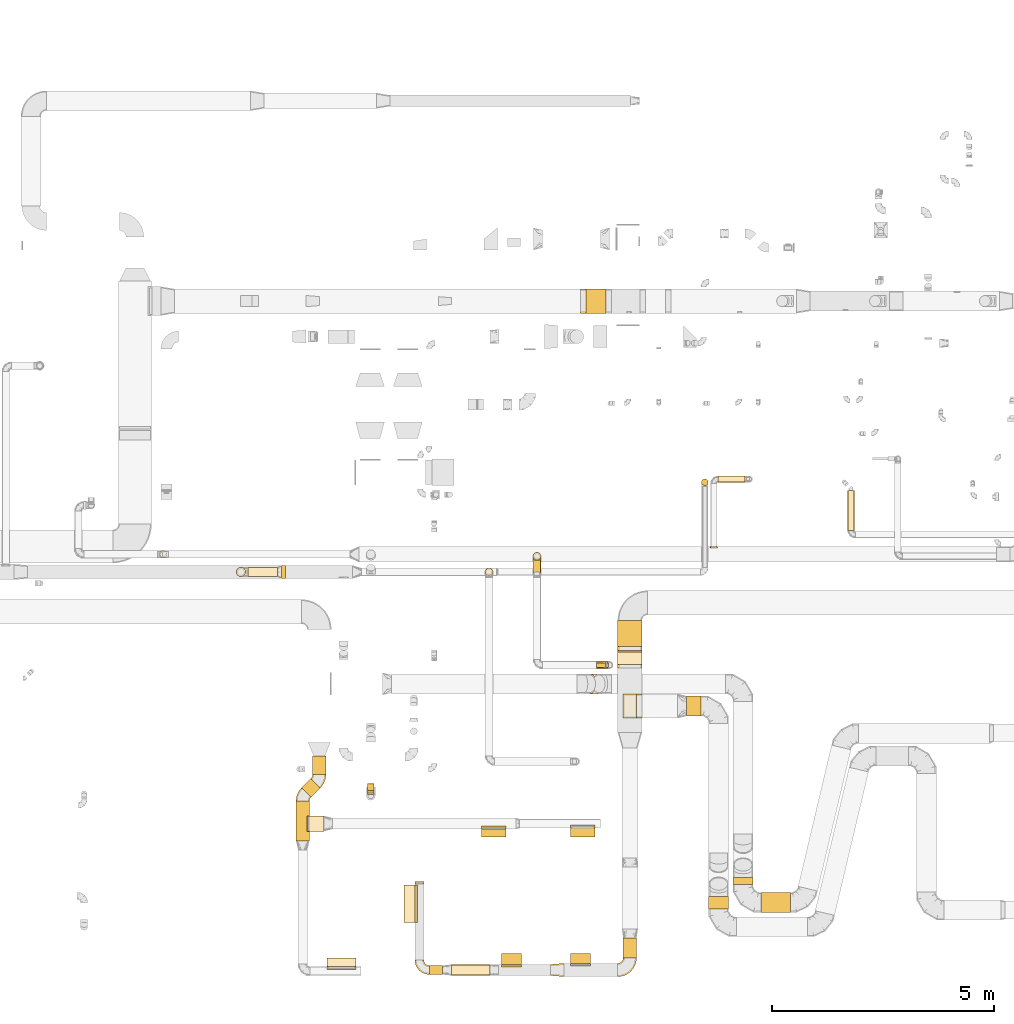
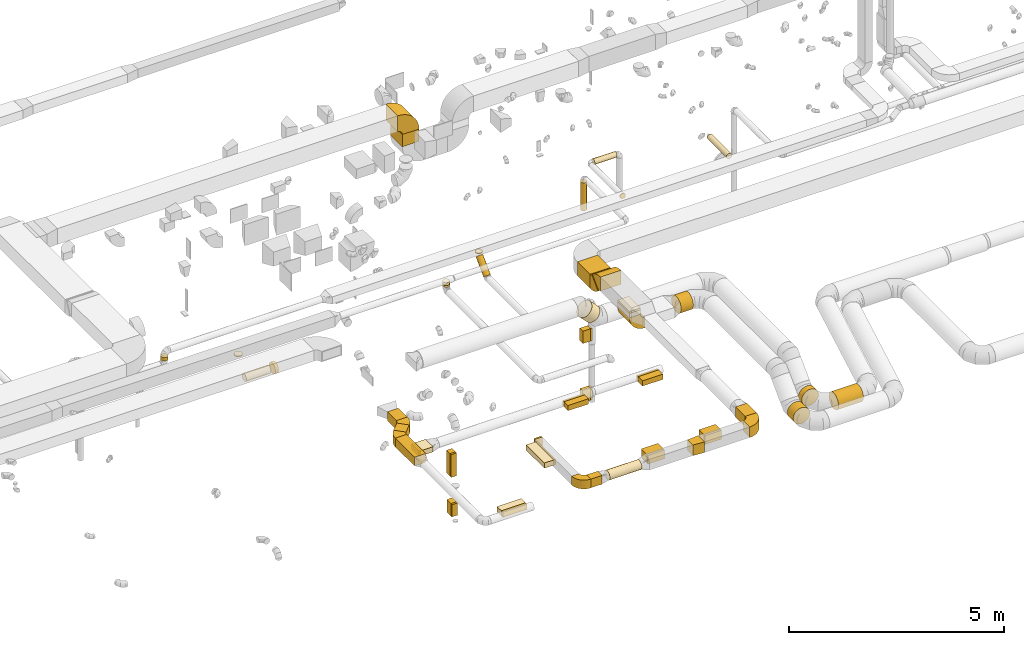
# One storey, part 7 of 97: 61 coverings.
"""IFC2X3 building model written with IfcOpenShell, lengths in millimetres."""

from ifc_helpers import new_model, entity, si_unit, converted_unit, derived_unit, direction, frame, frame_2d, origin, origin_2d_with_axis, place, context, subcontext, project, spatial, polyline, circle_curve, parameter, trimmed, segment, composite_curve, rectangle, circle, outline, extrude, element, save


model = new_model("IFC2X3")

# Units and contexts
model_context = context("Model", 3, precision=0.01, world=origin(), true_north=direction((6.12303176911189e-17, 1.0)))
body_context = subcontext(model_context, "Body", "Model", "MODEL_VIEW")
ifc_project = project(units=[si_unit("LENGTHUNIT", "METRE", prefix="MILLI"), si_unit("AREAUNIT", "SQUARE_METRE"), si_unit("VOLUMEUNIT", "CUBIC_METRE"), converted_unit("PLANEANGLEUNIT", "DEGREE", entity("IfcRatioMeasure", 0.0174532925199433), si_unit("PLANEANGLEUNIT", "RADIAN"), dimensions=[0, 0, 0, 0, 0, 0, 0]), si_unit("MASSUNIT", "GRAM", prefix="KILO"), derived_unit("MASSDENSITYUNIT", [(si_unit("MASSUNIT", "GRAM", prefix="KILO"), 1), (si_unit("LENGTHUNIT", "METRE"), -3)]), derived_unit("MOMENTOFINERTIAUNIT", [(si_unit("LENGTHUNIT", "METRE"), 4)]), si_unit("TIMEUNIT", "SECOND"), si_unit("FREQUENCYUNIT", "HERTZ"), si_unit("THERMODYNAMICTEMPERATUREUNIT", "DEGREE_CELSIUS"), derived_unit("THERMALTRANSMITTANCEUNIT", [(si_unit("MASSUNIT", "GRAM", prefix="KILO"), 1), (si_unit("THERMODYNAMICTEMPERATUREUNIT", "KELVIN"), -1), (si_unit("TIMEUNIT", "SECOND"), -3)]), derived_unit("VOLUMETRICFLOWRATEUNIT", [(si_unit("LENGTHUNIT", "METRE"), 3), (si_unit("TIMEUNIT", "SECOND"), -1)]), derived_unit("MASSFLOWRATEUNIT", [(si_unit("MASSUNIT", "GRAM", prefix="KILO"), 1), (si_unit("TIMEUNIT", "SECOND"), -1)]), derived_unit("ROTATIONALFREQUENCYUNIT", [(si_unit("TIMEUNIT", "SECOND"), -1)]), si_unit("ELECTRICCURRENTUNIT", "AMPERE"), si_unit("ELECTRICVOLTAGEUNIT", "VOLT"), si_unit("POWERUNIT", "WATT"), si_unit("FORCEUNIT", "NEWTON", prefix="KILO"), si_unit("ILLUMINANCEUNIT", "LUX"), si_unit("LUMINOUSFLUXUNIT", "LUMEN"), si_unit("LUMINOUSINTENSITYUNIT", "CANDELA"), derived_unit("USERDEFINED", [(si_unit("MASSUNIT", "GRAM", prefix="KILO"), -1), (si_unit("LENGTHUNIT", "METRE"), -2), (si_unit("TIMEUNIT", "SECOND"), 3), (si_unit("LUMINOUSFLUXUNIT", "LUMEN"), 1)]), derived_unit("LINEARVELOCITYUNIT", [(si_unit("LENGTHUNIT", "METRE"), 1), (si_unit("TIMEUNIT", "SECOND"), -1)]), si_unit("PRESSUREUNIT", "PASCAL"), derived_unit("USERDEFINED", [(si_unit("LENGTHUNIT", "METRE"), -2), (si_unit("MASSUNIT", "GRAM", prefix="KILO"), 1), (si_unit("TIMEUNIT", "SECOND"), -2)]), derived_unit("LINEARFORCEUNIT", [(si_unit("MASSUNIT", "GRAM", prefix="KILO"), 1), (si_unit("LENGTHUNIT", "METRE"), 1), (si_unit("TIMEUNIT", "SECOND"), -2), (si_unit("LENGTHUNIT", "METRE"), -1)]), derived_unit("PLANARFORCEUNIT", [(si_unit("MASSUNIT", "GRAM", prefix="KILO"), 1), (si_unit("LENGTHUNIT", "METRE"), 1), (si_unit("TIMEUNIT", "SECOND"), -2), (si_unit("LENGTHUNIT", "METRE"), -2)])], contexts=[model_context])

# Site, building, storey
site_placement = place(None, origin())
site = spatial("IfcSite", under=ifc_project, at=site_placement, CompositionType="ELEMENT")
building_placement = place(site_placement, origin())
building = spatial("IfcBuilding", under=site, at=building_placement, CompositionType="ELEMENT")
storey_placement = place(building_placement, frame((0.0, 0.0, -4900.0)))
storey = spatial("IfcBuildingStorey", under=building, at=storey_placement, CompositionType="ELEMENT", Elevation=-4900.0)

# Coverings
covering_1_placement = place(storey_placement, frame((51787.5, 2198.23, 2723.4)))
element("IfcCovering", 1, at=covering_1_placement, inside=storey, PredefinedType="INSULATION", context=body_context, shape_type="SweptSolid", body=[
    extrude(circle(Radius=225.0, at=origin_2d_with_axis()), frame((226.6, 0.0, 226.6), z_axis=(0.0, 1.0, 0.0), x_axis=(1.0, 0.0, 0.0)), (0.0, 0.0, 1.0), 161.222382101526),
])
covering_2_placement = place(storey_placement, frame((52414.1, 1571.63, 2723.4)))
element("IfcCovering", 2, at=covering_2_placement, inside=storey, PredefinedType="INSULATION", context=body_context, shape_type="SweptSolid", body=[
    extrude(circle(Radius=225.0, at=origin_2d_with_axis()), frame((0.0, 226.6, 226.6), z_axis=(1.0, 0.0, 0.0), x_axis=(0.0, -1.0, 0.0)), (0.0, 0.0, 1.0), 670.046048913268),
])
covering_3_placement = place(storey_placement, frame((41939.6, 3181.98, 3925.0)))
element("IfcCovering", 3, at=covering_3_placement, inside=storey, PredefinedType="INSULATION", context=body_context, shape_type="SweptSolid", body=[
    extrude(rectangle(XDim=895.203349597387, YDim=300.000000000001, at=origin_2d_with_axis()), frame((150.0, 447.6, 0.0), z_axis=(0.0, 0.0, 1.0), x_axis=(0.0, -1.0, 0.0)), (0.0, 0.0, 1.0), 250.0),
])
covering_4_placement = place(storey_placement, frame((42312.6, 4678.0, 3925.0)))
element("IfcCovering", 4, at=covering_4_placement, inside=storey, PredefinedType="INSULATION", context=body_context, shape_type="SweptSolid", body=[
    extrude(rectangle(XDim=419.303340347413, YDim=300.000000000001, at=origin_2d_with_axis()), frame((150.0, 209.65, 0.0), z_axis=(0.0, -4.68856683987599e-08, 1.0), x_axis=(0.0, 1.0, 4.68856683987599e-08)), (0.0, 0.0, 1.0), 250.0),
])
covering_5_placement = place(storey_placement, frame((42064.08, 4165.57, 3925.0)))
element("IfcCovering", 5, at=covering_5_placement, inside=storey, PredefinedType="INSULATION", context=body_context, shape_type="SweptSolid", body=[
    extrude(rectangle(XDim=299.684199460135, YDim=300.00000000001, at=origin_2d_with_axis()), frame((212.02, 212.02, 0.0), z_axis=(0.0, 0.0, 1.0), x_axis=(0.707106781186551, 0.707106781186544, 0.0)), (0.0, 0.0, 1.0), 250.0),
])
covering_6_placement = place(storey_placement, frame((42637.03, 348.86, 3975.0)))
element("IfcCovering", 6, at=covering_6_placement, inside=storey, PredefinedType="INSULATION", context=body_context, shape_type="SweptSolid", body=[
    extrude(rectangle(XDim=200.0, YDim=650.000000000008, at=origin_2d_with_axis()), frame((325.0, 100.0, 0.0), z_axis=(0.0, 0.0, 1.0), x_axis=(0.0, 1.0, 0.0)), (0.0, 0.0, 1.0), 150.0),
])
covering_7_placement = place(storey_placement, frame((42637.03, 280.22, 3975.0)))
element("IfcCovering", 7, at=covering_7_placement, inside=storey, PredefinedType="INSULATION", context=body_context, shape_type="SweptSolid", body=[
    extrude(rectangle(XDim=68.6460200160135, YDim=650.0, at=origin_2d_with_axis()), frame((325.0, 34.32, 0.0), z_axis=(0.0, 0.0, 1.0), x_axis=(0.0, -1.0, 0.0)), (0.0, 0.0, 1.0), 150.0),
])
covering_8_placement = place(storey_placement, frame((42183.5, 3398.53, 3975.0)))
element("IfcCovering", 8, at=covering_8_placement, inside=storey, PredefinedType="INSULATION", context=body_context, shape_type="SweptSolid", body=[
    extrude(rectangle(XDim=51.0960000000189, YDim=350.0, at=origin_2d_with_axis()), frame((25.55, 175.0, 0.0), z_axis=(0.0, 0.0, 1.0), x_axis=(-1.0, 0.0, 0.0)), (0.0, 0.0, 1.0), 150.0),
])
covering_9_placement = place(storey_placement, frame((42234.6, 3398.53, 3975.0)))
element("IfcCovering", 9, at=covering_9_placement, inside=storey, PredefinedType="INSULATION", context=body_context, shape_type="SweptSolid", body=[
    extrude(rectangle(XDim=330.308660000007, YDim=350.000000000001, at=origin_2d_with_axis()), frame((165.15, 175.0, 0.0)), (0.0, 0.0, 1.0), 150.0),
])
covering_10_placement = place(storey_placement, frame((48123.45, 3273.53, 3975.0)))
element("IfcCovering", 10, at=covering_10_placement, inside=storey, PredefinedType="INSULATION", context=body_context, shape_type="SweptSolid", body=[
    extrude(rectangle(XDim=199.999971499982, YDim=549.999999999996, at=origin_2d_with_axis()), frame((275.0, 100.0, 0.0), z_axis=(0.0, 0.0, 1.0), x_axis=(0.0, -1.0, 0.0)), (0.0, 0.0, 1.0), 150.0),
])
covering_11_placement = place(storey_placement, frame((46119.41, 3273.53, 3975.0)))
element("IfcCovering", 11, at=covering_11_placement, inside=storey, PredefinedType="INSULATION", context=body_context, shape_type="SweptSolid", body=[
    extrude(rectangle(XDim=179.999983999988, YDim=549.999999999996, at=origin_2d_with_axis()), frame((275.0, 90.0, 0.0), z_axis=(0.0, 0.0, 1.0), x_axis=(0.0, -1.0, 0.0)), (0.0, 0.0, 1.0), 150.0),
])
covering_12_placement = place(storey_placement, frame((46119.41, 3453.53, 3975.0)))
element("IfcCovering", 12, at=covering_12_placement, inside=storey, PredefinedType="INSULATION", context=body_context, shape_type="SweptSolid", body=[
    extrude(rectangle(XDim=549.999999999996, YDim=64.4934596215618, at=origin_2d_with_axis()), frame((275.0, 32.25, 0.0)), (0.0, 0.0, 1.0), 150.0),
])
covering_13_placement = place(storey_placement, frame((48123.45, 3473.53, 3975.0)))
element("IfcCovering", 13, at=covering_13_placement, inside=storey, PredefinedType="INSULATION", context=body_context, shape_type="SweptSolid", body=[
    extrude(rectangle(XDim=549.999999999996, YDim=68.6460200160276, at=origin_2d_with_axis()), frame((275.0, 34.32, 0.0)), (0.0, 0.0, 1.0), 150.0),
])
covering_14_placement = place(storey_placement, frame((40857.67, 9138.41, 3040.4)))
element("IfcCovering", 14, at=covering_14_placement, inside=storey, PredefinedType="INSULATION", context=body_context, shape_type="SweptSolid", body=[
    extrude(circle(Radius=105.0, at=origin_2d_with_axis()), frame((0.0, 106.6, 106.6), z_axis=(1.0, 0.0, 0.0), x_axis=(0.0, 1.0, 0.0)), (0.0, 0.0, 1.0), 663.702439249885),
])
covering_15_placement = place(storey_placement, frame((41611.37, 9093.41, 2995.4)))
element("IfcCovering", 15, at=covering_15_placement, inside=storey, PredefinedType="INSULATION", context=body_context, shape_type="SweptSolid", body=[
    extrude(circle(Radius=150.0, at=origin_2d_with_axis()), frame((0.0, 151.6, 151.6), z_axis=(1.0, 0.0, 0.0), x_axis=(0.0, 1.0, 0.0)), (0.0, 0.0, 1.0), 90.0000000000315),
])
covering_16_placement = place(storey_placement, frame((51076.93, 11188.41, 3100.0)))
element("IfcCovering", 16, at=covering_16_placement, inside=storey, PredefinedType="INSULATION", context=body_context, shape_type="SweptSolid", body=[
    extrude(circle(Radius=75.0, at=origin_2d_with_axis()), frame((76.6, 76.6, 0.0)), (0.0, 0.0, 1.0), 799.999999999995),
])
covering_17_placement = place(storey_placement, frame((46200.29, 9155.91, 3865.0)))
element("IfcCovering", 17, at=covering_17_placement, inside=storey, PredefinedType="INSULATION", context=body_context, shape_type="SweptSolid", body=[
    extrude(circle(Radius=87.5, at=origin_2d_with_axis()), frame((89.1, 89.1, 0.0), z_axis=(0.0, 1.27955975282367e-05, 1.0), x_axis=(0.0, 1.0, -1.27955975282367e-05)), (0.0, 0.0, 1.0), 52.503404808983),
])
covering_18_placement = place(storey_placement, frame((49188.6, 7564.08, 3780.0)))
element("IfcCovering", 18, at=covering_18_placement, inside=storey, PredefinedType="INSULATION", context=body_context, shape_type="SweptSolid", body=[
    extrude(rectangle(XDim=586.289807584145, YDim=549.999999999996, at=origin_2d_with_axis()), frame((275.0, 293.14, 0.0), z_axis=(0.0, 0.0, 1.0), x_axis=(0.0, -1.0, 0.0)), (0.0, 0.0, 1.0), 400.0),
])
covering_19_placement = place(storey_placement, frame((49188.6, 7163.23, 3933.77)))
element("IfcCovering", 19, at=covering_19_placement, inside=storey, PredefinedType="INSULATION", context=body_context, shape_type="SweptSolid", body=[
    extrude(rectangle(XDim=41.888132824211, YDim=400.0, at=origin_2d_with_axis()), frame((0.0, 156.23, 156.23), z_axis=(1.0, 0.0, 0.0), x_axis=(0.0, -0.707106781186528, 0.707106781186567)), (0.0, 0.0, 1.0), 550.000000000005),
])
covering_20_placement = place(storey_placement, frame((49313.6, 548.87, 4050.0)))
element("IfcCovering", 20, at=covering_20_placement, inside=storey, PredefinedType="INSULATION", context=body_context, shape_type="SweptSolid", body=[
    extrude(rectangle(XDim=446.507916250006, YDim=300.000000000001, at=origin_2d_with_axis()), frame((150.0, 223.25, 0.0), z_axis=(0.0, 9.6225856577518e-09, 1.0), x_axis=(0.0, -1.0, 9.6225856577518e-09)), (0.0, 0.0, 1.0), 300.0),
])
covering_21_placement = place(storey_placement, frame((47673.94, 123.87, 4050.0)))
element("IfcCovering", 21, at=covering_21_placement, inside=storey, PredefinedType="INSULATION", context=body_context, shape_type="SweptSolid", body=[
    extrude(outline(polyline([(-161.94, -137.03), (139.1, -137.03), (159.86, 112.11), (-137.03, 161.94), (-161.94, -137.03)])), frame((150.0, 150.0, 0.0), z_axis=(0.0, 0.0, 1.0), x_axis=(-0.996545758244898, -0.0830454798535242, 0.0)), (0.0, 0.0, 1.0), 300.0),
])
covering_22_placement = place(storey_placement, frame((48125.01, 418.87, 4075.0)))
element("IfcCovering", 22, at=covering_22_placement, inside=storey, PredefinedType="INSULATION", context=body_context, shape_type="SweptSolid", body=[
    extrude(rectangle(XDim=229.999999999978, YDim=450.000000000002, at=origin_2d_with_axis()), frame((225.0, 115.0, 0.0), z_axis=(0.0, 0.0, 1.0), x_axis=(0.0, 1.0, 0.0)), (0.0, 0.0, 1.0), 250.0),
])
covering_23_placement = place(storey_placement, frame((46575.54, 393.87, 4075.0)))
element("IfcCovering", 23, at=covering_23_placement, inside=storey, PredefinedType="INSULATION", context=body_context, shape_type="SweptSolid", body=[
    extrude(rectangle(XDim=254.999999999911, YDim=450.000000000002, at=origin_2d_with_axis()), frame((225.0, 127.5, 0.0), z_axis=(0.0, 0.0, 1.0), x_axis=(0.0, 1.0, 0.0)), (0.0, 0.0, 1.0), 250.0),
])
for number, where in (
    (24, (48125.01, 367.78, 4075.0)),
    (25, (46575.54, 342.78, 4075.0)),
):
    element("IfcCovering", number, at=place(storey_placement, frame(where)), inside=storey, PredefinedType="INSULATION", context=body_context, shape_type="SweptSolid", body=[
        extrude(rectangle(XDim=450.000000000002, YDim=51.0959999999993, at=origin_2d_with_axis()), frame((225.0, 25.55, 0.0), z_axis=(0.0, 0.0, 1.0), x_axis=(-1.0, 0.0, 0.0)), (0.0, 0.0, 1.0), 250.0),
    ])
covering_24_placement = place(storey_placement, frame((45443.8, 147.28, 4073.4)))
element("IfcCovering", 26, at=covering_24_placement, inside=storey, PredefinedType="INSULATION", context=body_context, shape_type="SweptSolid", body=[
    extrude(circle(Radius=125.0, at=origin_2d_with_axis()), frame((0.0, 126.6, 126.6), z_axis=(1.0, 0.0, 0.0), x_axis=(0.0, -1.0, 0.0)), (0.0, 0.0, 1.0), 862.329403500012),
])
covering_25_placement = place(storey_placement, frame((44943.59, 173.87, 4075.0)))
element("IfcCovering", 27, at=covering_25_placement, inside=storey, PredefinedType="INSULATION", context=body_context, shape_type="SweptSolid", body=[
    extrude(rectangle(XDim=300.204466499987, YDim=200.0, at=origin_2d_with_axis()), frame((150.1, 100.0, 0.0), z_axis=(0.0, 0.0, 1.0), x_axis=(-1.0, 0.0, 0.0)), (0.0, 0.0, 1.0), 250.0),
])
covering_26_placement = place(storey_placement, frame((44618.59, 2217.15, 4075.0)))
element("IfcCovering", 28, at=covering_26_placement, inside=storey, PredefinedType="INSULATION", context=body_context, shape_type="SweptSolid", body=[
    extrude(rectangle(XDim=50.0000000000005, YDim=199.999999999998, at=origin_2d_with_axis()), frame((100.0, 25.0, 0.0), z_axis=(0.0, 0.0, 1.0), x_axis=(0.0, -1.0, 0.0)), (0.0, 0.0, 1.0), 250.0),
])
covering_27_placement = place(storey_placement, frame((44368.59, 1341.12, 4125.0)))
element("IfcCovering", 29, at=covering_27_placement, inside=storey, PredefinedType="INSULATION", context=body_context, shape_type="SweptSolid", body=[
    extrude(rectangle(XDim=254.999966500009, YDim=850.0, at=origin_2d_with_axis()), frame((127.5, 425.0, 0.0), z_axis=(0.0, 0.0, 1.0), x_axis=(-1.0, 0.0, 0.0)), (0.0, 0.0, 1.0), 150.0),
])
covering_28_placement = place(storey_placement, frame((44623.59, 1341.12, 4125.0)))
element("IfcCovering", 30, at=covering_28_placement, inside=storey, PredefinedType="INSULATION", context=body_context, shape_type="SweptSolid", body=[
    extrude(rectangle(XDim=850.0, YDim=51.0960000000016, at=origin_2d_with_axis()), frame((25.55, 425.0, 0.0), z_axis=(0.0, 0.0, 1.0), x_axis=(0.0, -1.0, 0.0)), (0.0, 0.0, 1.0), 150.0),
])
covering_29_placement = place(storey_placement, frame((49313.6, 5948.55, 3875.0)))
element("IfcCovering", 31, at=covering_29_placement, inside=storey, PredefinedType="INSULATION", context=body_context, shape_type="SweptSolid", body=[
    extrude(rectangle(XDim=550.000000000001, YDim=300.000000000001, at=origin_2d_with_axis()), frame((150.0, 275.0, 0.0), z_axis=(0.0, 0.0, 1.0), x_axis=(0.0, 1.0, 0.0)), (0.0, 0.0, 1.0), 129.99999999994),
])
covering_30_placement = place(storey_placement, frame((49313.6, 5948.55, 4005.0)))
element("IfcCovering", 32, at=covering_30_placement, inside=storey, PredefinedType="INSULATION", context=body_context, shape_type="SweptSolid", body=[
    extrude(rectangle(XDim=550.0, YDim=300.000000000001, at=origin_2d_with_axis()), frame((150.0, 275.0, 0.0), z_axis=(0.0, 0.0, 1.0), x_axis=(0.0, 1.0, 0.0)), (0.0, 0.0, 1.0), 51.0960000001598),
])
covering_31_placement = place(storey_placement, frame((50735.84, 5996.95, 3373.4)))
element("IfcCovering", 33, at=covering_31_placement, inside=storey, PredefinedType="INSULATION", context=body_context, shape_type="SweptSolid", body=[
    extrude(circle(Radius=225.0, at=origin_2d_with_axis()), frame((0.0, 226.6, 226.6), z_axis=(1.0, 0.0, 4.02178412496961e-08), x_axis=(0.0, 1.0, 0.0)), (0.0, 0.0, 1.0), 328.315702253714),
])
covering_32_placement = place(storey_placement, frame((51237.56, 1648.73, 2723.4)))
element("IfcCovering", 34, at=covering_32_placement, inside=storey, PredefinedType="INSULATION", context=body_context, shape_type="SweptSolid", body=[
    extrude(circle(Radius=225.0, at=origin_2d_with_axis()), frame((226.6, 0.0, 226.6), z_axis=(0.0, 1.0, 0.0), x_axis=(1.0, 0.0, 0.0)), (0.0, 0.0, 1.0), 279.135993523077),
])
covering_33_placement = place(storey_placement, frame((47279.85, 9509.05, 4221.78)))
element("IfcCovering", 35, at=covering_33_placement, inside=storey, PredefinedType="INSULATION", context=body_context, shape_type="SweptSolid", body=[
    extrude(circle(Radius=87.5, at=origin_2d_with_axis()), frame((89.1, 89.1, 0.0), z_axis=(0.0, 0.0, 1.0), x_axis=(0.0, 1.0, 0.0)), (0.0, 0.0, 1.0), 8.22330470336942),
])
covering_34_placement = place(storey_placement, frame((48711.88, 7071.24, 2675.0)))
element("IfcCovering", 36, at=covering_34_placement, inside=storey, PredefinedType="INSULATION", context=body_context, shape_type="SweptSolid", body=[
    extrude(rectangle(XDim=204.999967249919, YDim=150.000000000001, at=origin_2d_with_axis()), frame((102.5, 75.0, 0.0), z_axis=(0.0, 0.0, 1.0), x_axis=(-1.0, 0.0, 0.0)), (0.0, 0.0, 1.0), 350.0),
])
covering_35_placement = place(storey_placement, frame((48711.74, 7096.24, 975.0)))
element("IfcCovering", 37, at=covering_35_placement, inside=storey, PredefinedType="INSULATION", context=body_context, shape_type="SweptSolid", body=[
    extrude(rectangle(XDim=217.638826253178, YDim=100.000000000001, at=origin_2d_with_axis()), frame((108.82, 50.0, 0.0), z_axis=(0.0, 0.0, 1.0), x_axis=(-1.0, 0.0, 0.0)), (0.0, 0.0, 1.0), 350.000000000001),
])
covering_36_placement = place(storey_placement, frame((48929.38, 7096.24, 975.0)))
element("IfcCovering", 38, at=covering_36_placement, inside=storey, PredefinedType="INSULATION", context=body_context, shape_type="SweptSolid", body=[
    extrude(rectangle(XDim=100.000000000001, YDim=51.0960000000102, at=origin_2d_with_axis()), frame((25.55, 50.0, 0.0), z_axis=(0.0, 0.0, 1.0), x_axis=(0.0, -1.0, 0.0)), (0.0, 0.0, 1.0), 350.0),
])
covering_37_placement = place(storey_placement, frame((48916.88, 7071.24, 2675.0)))
element("IfcCovering", 39, at=covering_37_placement, inside=storey, PredefinedType="INSULATION", context=body_context, shape_type="SweptSolid", body=[
    extrude(rectangle(XDim=150.000000000001, YDim=51.0960000001488, at=origin_2d_with_axis()), frame((25.55, 75.0, 0.0), z_axis=(0.0, 0.0, 1.0), x_axis=(0.0, -1.0, 0.0)), (0.0, 0.0, 1.0), 350.0),
])
covering_38_placement = place(storey_placement, frame((43550.66, 4318.32, 2375.0)))
element("IfcCovering", 40, at=covering_38_placement, inside=storey, PredefinedType="INSULATION", context=body_context, shape_type="SweptSolid", body=[
    extrude(rectangle(XDim=159.99999999999, YDim=150.000000000002, at=origin_2d_with_axis()), frame((75.0, 80.0, 0.0), z_axis=(0.0, 0.0, 1.0), x_axis=(-9.81578986625269e-06, 1.0, 0.0)), (0.0, 0.0, 1.0), 649.999999999999),
])
covering_39_placement = place(storey_placement, frame((43550.66, 4280.82, 1275.0)))
element("IfcCovering", 41, at=covering_39_placement, inside=storey, PredefinedType="INSULATION", context=body_context, shape_type="SweptSolid", body=[
    extrude(rectangle(XDim=189.999999999926, YDim=150.000000000001, at=origin_2d_with_axis()), frame((75.0, 95.0, 0.0), z_axis=(0.0, 0.0, 1.0), x_axis=(0.0, 1.0, 0.0)), (0.0, 0.0, 1.0), 350.000000000001),
])
covering_40_placement = place(storey_placement, frame((43550.66, 4267.22, 2375.0)))
element("IfcCovering", 42, at=covering_40_placement, inside=storey, PredefinedType="INSULATION", context=body_context, shape_type="SweptSolid", body=[
    extrude(rectangle(XDim=150.000000000002, YDim=51.0960000000012, at=origin_2d_with_axis()), frame((75.0, 25.55, 0.0), z_axis=(0.0, 0.0, 1.0), x_axis=(-1.0, -9.81578986625197e-06, 0.0)), (0.0, 0.0, 1.0), 649.999999999999),
])
covering_41_placement = place(storey_placement, frame((43550.66, 4229.72, 1275.0)))
element("IfcCovering", 43, at=covering_41_placement, inside=storey, PredefinedType="INSULATION", context=body_context, shape_type="SweptSolid", body=[
    extrude(rectangle(XDim=150.000000000001, YDim=51.0960000001477, at=origin_2d_with_axis()), frame((75.0, 25.55, 0.0), z_axis=(0.0, 0.0, 1.0), x_axis=(-1.0, 0.0, 0.0)), (0.0, 0.0, 1.0), 350.0),
])
covering_42_placement = place(storey_placement, frame((54370.31, 10183.58, 4038.4)))
element("IfcCovering", 44, at=covering_42_placement, inside=storey, PredefinedType="INSULATION", context=body_context, shape_type="SweptSolid", body=[
    extrude(circle(Radius=75.0, at=origin_2d_with_axis()), frame((76.6, 0.0, 76.6), z_axis=(0.0, 1.0, 0.0), x_axis=(-1.0, 0.0, 0.0)), (0.0, 0.0, 1.0), 895.739513762699),
])
covering_43_placement = place(storey_placement, frame((48388.84, 6496.49, 3556.46)))
element("IfcCovering", 45, at=covering_43_placement, inside=storey, PredefinedType="INSULATION", context=body_context, shape_type="SweptSolid", body=[
    extrude(circle(Radius=225.0, at=origin_2d_with_axis()), frame((376.38, 226.6, 160.69), z_axis=(-0.707106781186547, 0.0, 0.707106781186548), x_axis=(0.0, 1.0, 0.0)), (0.0, 0.0, 1.0), 305.025253169393),
])
covering_44_placement = place(storey_placement, frame((51454.28, 11258.75, 4223.4)))
element("IfcCovering", 46, at=covering_44_placement, inside=storey, PredefinedType="INSULATION", context=body_context, shape_type="SweptSolid", body=[
    extrude(circle(Radius=75.0, at=origin_2d_with_axis()), frame((0.0, 76.6, 76.6), z_axis=(1.0, 0.0, 0.0), x_axis=(0.0, -1.0, 0.0)), (0.0, 0.0, 1.0), 600.000000000011),
])
covering_45_placement = place(storey_placement, frame((51277.68, 9787.05, 4223.4)))
element("IfcCovering", 47, at=covering_45_placement, inside=storey, PredefinedType="INSULATION", context=body_context, shape_type="SweptSolid", body=[
    extrude(circle(Radius=75.0, at=origin_2d_with_axis()), frame((76.6, 0.0, 76.6), z_axis=(0.0, 1.0, 0.0), x_axis=(-1.0, 0.0, 0.0)), (0.0, 0.0, 1.0), 26.0959999999964),
])
covering_46_placement = place(storey_placement, frame((38850.72, 9554.05, 4105.0)))
element("IfcCovering", 48, at=covering_46_placement, inside=storey, PredefinedType="INSULATION", context=body_context, shape_type="SweptSolid", body=[
    extrude(circle(Radius=87.5, at=origin_2d_with_axis()), frame((89.1, 89.1, 0.0), z_axis=(0.0, 0.0, 1.0), x_axis=(0.0, -1.0, 0.0)), (0.0, 0.0, 1.0), 95.0000000000028),
])
covering_47_placement = place(storey_placement, frame((40591.08, 9138.41, 3855.0)))
element("IfcCovering", 49, at=covering_47_placement, inside=storey, PredefinedType="INSULATION", context=body_context, shape_type="SweptSolid", body=[
    extrude(circle(Radius=105.0, at=origin_2d_with_axis()), frame((106.6, 106.6, 0.0)), (0.0, 0.0, 1.0), 26.096000000207),
])
covering_48_placement = place(storey_placement, frame((48477.19, 15074.1, 3500.0)))
element("IfcCovering", 50, at=covering_48_placement, inside=storey, PredefinedType="INSULATION", context=body_context, shape_type="SweptSolid", body=[
    extrude(rectangle(XDim=550.000000000001, YDim=450.000000000002, at=origin_2d_with_axis()), frame((225.0, 275.0, 0.0), z_axis=(0.0, 0.0, 1.0), x_axis=(0.0, 1.0, 0.0)), (0.0, 0.0, 1.0), 349.999974999914),
])
covering_49_placement = place(storey_placement, frame((46200.29, 9155.91, 3917.5)))
element("IfcCovering", 51, at=covering_49_placement, inside=storey, PredefinedType="INSULATION", context=body_context, shape_type="SweptSolid", body=[
    extrude(circle(Radius=87.5, at=origin_2d_with_axis()), frame((89.1, 89.1, 0.0), z_axis=(0.0, 1.27955974602232e-05, 1.0), x_axis=(-1.0, 0.0, 0.0)), (0.0, 0.0, 1.0), 76.4047997123457),
])
covering_50_placement = place(storey_placement, frame((47279.85, 9509.05, 4230.0)))
element("IfcCovering", 52, at=covering_50_placement, inside=storey, PredefinedType="INSULATION", context=body_context, shape_type="SweptSolid", body=[
    extrude(circle(Radius=87.5, at=origin_2d_with_axis()), frame((89.1, 89.1, 0.0), z_axis=(0.0, 0.0, 1.0), x_axis=(0.0, -1.0, 0.0)), (0.0, 0.0, 1.0), 26.0960000000224),
])
covering_51_placement = place(storey_placement, frame((47279.85, 9141.29, 3713.14)))
element("IfcCovering", 53, at=covering_51_placement, inside=storey, PredefinedType="INSULATION", context=body_context, shape_type="SweptSolid", body=[
    extrude(circle(Radius=87.5, at=origin_2d_with_axis()), frame((89.1, 63.47, 63.47), z_axis=(0.0, 0.707106781186546, 0.707106781186549), x_axis=(1.0, 0.0, 0.0)), (0.0, 0.0, 1.0), 504.558441227135),
])
covering_52_placement = place(storey_placement, frame((41938.0, 4075.59, 3925.0)))
element("IfcCovering", 54, at=covering_52_placement, inside=storey, PredefinedType="INSULATION", context=body_context, shape_type="SweptSolid", body=[
    extrude(outline(composite_curve([segment(polyline([(-146.34, 8.84), (65.79, -203.29)]), True, "CONTINUOUS"), segment(trimmed(circle_curve(frame_2d((-234.73, 97.23), x_axis=(1.0, 0.0)), 425.0), [parameter(315.0)], [parameter(0.0)], True, "PARAMETER"), True, "CONTINUOUS"), segment(polyline([(190.27, 97.23), (-109.73, 97.23)]), True, "CONTINUOUS"), segment(trimmed(circle_curve(frame_2d((-234.73, 97.23), x_axis=(1.0, 0.0)), 125.0), [parameter(315.0)], [parameter(360.0)], True, "PARAMETER"), False, "CONTINUOUS")], self_intersect=False)), frame((191.87, 98.82, 0.0), z_axis=(0.0, 0.0, -1.0), x_axis=(-0.707106781186536, 0.707106781186559, 0.0)), (0.0, 0.0, -1.0), 250.0),
])
covering_53_placement = place(storey_placement, frame((49188.6, 7191.25, 3778.4)))
element("IfcCovering", 55, at=covering_53_placement, inside=storey, PredefinedType="INSULATION", context=body_context, shape_type="SweptSolid", body=[
    extrude(outline(composite_curve([segment(polyline([(-152.4, -114.9), (247.6, -114.9)]), True, "CONTINUOUS"), segment(trimmed(circle_curve(frame_2d((-277.4, -114.9), x_axis=(0.707106781186553, 0.707106781186525)), 525.0), [parameter(315.0)], [parameter(0.0)], True, "PARAMETER"), True, "CONTINUOUS"), segment(polyline([(93.83, 256.33), (-189.02, -26.52)]), True, "CONTINUOUS"), segment(trimmed(circle_curve(frame_2d((-277.4, -114.9), x_axis=(0.707106781186553, 0.707106781186525)), 125.0), [parameter(315.0)], [parameter(360.0)], True, "PARAMETER"), False, "CONTINUOUS")], self_intersect=False)), frame((0.0, 257.92, 249.19), z_axis=(1.0, 0.0, 0.0), x_axis=(0.0, -0.707106781186546, -0.707106781186549)), (0.0, 0.0, 1.0), 549.999999999996),
])
covering_54_placement = place(storey_placement, frame((49188.6, 7073.24, 3961.79)))
element("IfcCovering", 56, at=covering_54_placement, inside=storey, PredefinedType="INSULATION", context=body_context, shape_type="SweptSolid", body=[
    extrude(outline(composite_curve([segment(polyline([(-189.02, 26.52), (93.83, -256.33)]), True, "CONTINUOUS"), segment(trimmed(circle_curve(frame_2d((-277.4, 114.9), x_axis=(1.0, 0.0)), 525.0), [parameter(315.0)], [parameter(0.0)], True, "PARAMETER"), True, "CONTINUOUS"), segment(polyline([(247.6, 114.9), (-152.4, 114.9)]), True, "CONTINUOUS"), segment(trimmed(circle_curve(frame_2d((-277.4, 114.9), x_axis=(1.0, 0.0)), 125.0), [parameter(315.0)], [parameter(360.0)], True, "PARAMETER"), False, "CONTINUOUS")], self_intersect=False)), frame((0.0, 116.5, 190.61), z_axis=(-1.0, 0.0, 0.0), x_axis=(0.0, 0.707106781186555, 0.707106781186541)), (0.0, 0.0, -1.0), 549.999999999996),
])
covering_55_placement = place(storey_placement, frame((49187.0, 122.28, 4050.0)))
element("IfcCovering", 57, at=covering_55_placement, inside=storey, PredefinedType="INSULATION", context=body_context, shape_type="SweptSolid", body=[
    extrude(outline(composite_curve([segment(polyline([(-137.5, 12.5), (-137.5, -287.5)]), True, "CONTINUOUS"), segment(trimmed(circle_curve(frame_2d((-137.5, 137.5), x_axis=(1.0, 0.0)), 425.0), [parameter(270.0)], [parameter(0.0)], True, "PARAMETER"), True, "CONTINUOUS"), segment(polyline([(287.5, 137.5), (-12.5, 137.5)]), True, "CONTINUOUS"), segment(trimmed(circle_curve(frame_2d((-137.5, 137.5), x_axis=(1.0, 0.0)), 125.0), [parameter(270.0)], [parameter(360.0)], True, "PARAMETER"), False, "CONTINUOUS")], self_intersect=False)), frame((139.1, 289.1, 0.0), z_axis=(0.0, 0.0, -1.0), x_axis=(0.0, -1.0, 0.0)), (0.0, 0.0, -1.0), 300.0),
])
covering_56_placement = place(storey_placement, frame((44617.0, 172.28, 4075.0)))
element("IfcCovering", 58, at=covering_56_placement, inside=storey, PredefinedType="INSULATION", context=body_context, shape_type="SweptSolid", body=[
    extrude(outline(composite_curve([segment(polyline([(-112.5, -12.5), (-112.5, -212.5)]), True, "CONTINUOUS"), segment(trimmed(circle_curve(frame_2d((-112.5, 112.5), x_axis=(1.0, 0.0)), 325.0), [parameter(270.0)], [parameter(0.0)], True, "PARAMETER"), True, "CONTINUOUS"), segment(polyline([(212.5, 112.5), (12.5, 112.5)]), True, "CONTINUOUS"), segment(trimmed(circle_curve(frame_2d((-112.5, 112.5), x_axis=(1.0, 0.0)), 125.0), [parameter(270.0)], [parameter(360.0)], True, "PARAMETER"), False, "CONTINUOUS")], self_intersect=False)), frame((214.1, 214.1, 0.0), z_axis=(0.0, 0.0, -1.0), x_axis=(-1.0, 0.0, 0.0)), (0.0, 0.0, -1.0), 250.0),
])
covering_57_placement = place(storey_placement, frame((49312.0, 5948.55, 3448.4)))
element("IfcCovering", 59, at=covering_57_placement, inside=storey, PredefinedType="INSULATION", context=body_context, shape_type="SweptSolid", body=[
    extrude(outline(composite_curve([segment(polyline([(-12.5, -137.5), (287.5, -137.5)]), True, "CONTINUOUS"), segment(trimmed(circle_curve(frame_2d((-137.5, -137.5), x_axis=(0.0, 1.0)), 425.0), [parameter(270.0)], [parameter(0.0)], True, "PARAMETER"), True, "CONTINUOUS"), segment(polyline([(-137.5, 287.5), (-137.5, -12.5)]), True, "CONTINUOUS"), segment(trimmed(circle_curve(frame_2d((-137.5, -137.5), x_axis=(0.0, 1.0)), 125.0), [parameter(270.0)], [parameter(360.0)], True, "PARAMETER"), False, "CONTINUOUS")], self_intersect=False)), frame((289.1, 0.0, 289.1), z_axis=(0.0, 1.0, 0.0), x_axis=(0.0, 0.0, -1.0)), (0.0, 0.0, 1.0), 550.000000000001),
])
covering_58_placement = place(storey_placement, frame((42274.39, 4375.89, 3925.0)))
element("IfcCovering", 60, at=covering_58_placement, inside=storey, PredefinedType="INSULATION", context=body_context, shape_type="SweptSolid", body=[
    extrude(outline(composite_curve([segment(polyline([(-146.34, 8.84), (65.79, -203.29)]), True, "CONTINUOUS"), segment(trimmed(circle_curve(frame_2d((-234.73, 97.23), x_axis=(1.0, 0.0)), 425.0), [parameter(315.0)], [parameter(0.0)], True, "PARAMETER"), True, "CONTINUOUS"), segment(polyline([(190.27, 97.23), (-109.73, 97.23)]), True, "CONTINUOUS"), segment(trimmed(circle_curve(frame_2d((-234.73, 97.23), x_axis=(1.0, 0.0)), 125.0), [parameter(315.0)], [parameter(360.0)], True, "PARAMETER"), False, "CONTINUOUS")], self_intersect=False)), frame((147.93, 204.89, 0.0), z_axis=(-4.68856647490176e-08, 4.68856647490181e-08, -1.0), x_axis=(0.707106781186543, -0.707106781186549, -6.63063429689391e-08)), (0.0, 0.0, -1.0), 250.0),
])
covering_59_placement = place(storey_placement, frame((48350.6, 15074.1, 3848.4)))
element("IfcCovering", 61, at=covering_59_placement, inside=storey, PredefinedType="INSULATION", context=body_context, shape_type="SweptSolid", body=[
    extrude(outline(composite_curve([segment(polyline([(-175.0, 50.0), (-175.0, -400.0)]), True, "CONTINUOUS"), segment(trimmed(circle_curve(frame_2d((-175.0, 175.0), x_axis=(1.0, 0.0)), 575.0), [parameter(270.0)], [parameter(0.0)], True, "PARAMETER"), True, "CONTINUOUS"), segment(polyline([(400.0, 175.0), (-50.0, 175.0)]), True, "CONTINUOUS"), segment(trimmed(circle_curve(frame_2d((-175.0, 175.0), x_axis=(1.0, 0.0)), 125.0), [parameter(270.0)], [parameter(360.0)], True, "PARAMETER"), False, "CONTINUOUS")], self_intersect=False)), frame((176.6, 0.0, 176.6), z_axis=(0.0, -1.0, 0.0), x_axis=(0.0, 0.0, 1.0)), (0.0, 0.0, -1.0), 550.000000000001),
])

save(model, "model.ifc")
